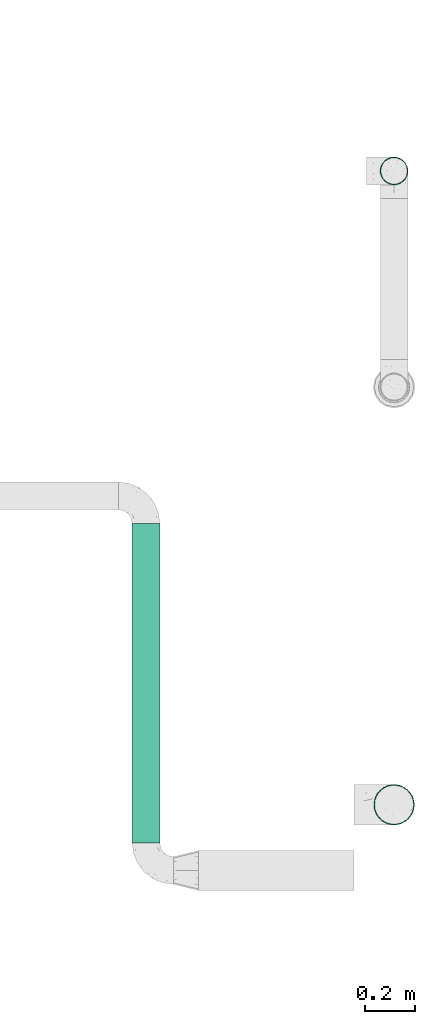
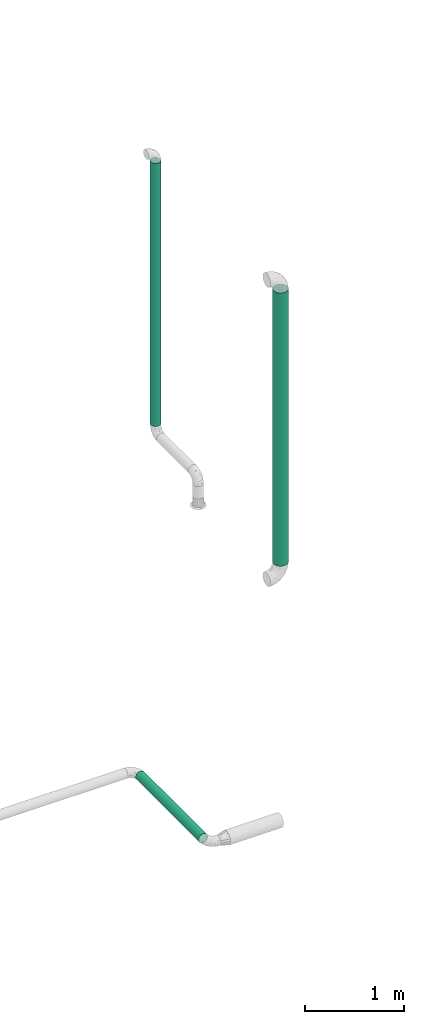
# One storey, part 20 of 123: 3 flow segments.
"""IFC2X3 building model written with IfcOpenShell, lengths in millimetres."""

from ifc_helpers import new_model, entity, si_unit, converted_unit, derived_unit, direction, frame, origin_with_axes, origin_2d_with_axis, place, context, subcontext, project, spatial, hollow_circle, extrude, source, transform, mapped, material, layer, layer_set, layer_usage, type_object, element, save


model = new_model("IFC2X3")

# Units and contexts
model_context = context("Model", 3, precision=1e-05, world=origin_with_axes(), true_north=direction((0.0, 1.0)))
body_context = subcontext(model_context, "Body", "Model", "MODEL_VIEW")
ifc_project = project(units=[si_unit("AREAUNIT", "SQUARE_METRE"), si_unit("VOLUMEUNIT", "CUBIC_METRE", prefix="DECI"), si_unit("TIMEUNIT", "SECOND"), si_unit("THERMODYNAMICTEMPERATUREUNIT", "DEGREE_CELSIUS"), si_unit("PRESSUREUNIT", "PASCAL"), si_unit("MASSUNIT", "GRAM", prefix="KILO"), si_unit("LENGTHUNIT", "METRE", prefix="MILLI"), si_unit("POWERUNIT", "WATT"), si_unit("ELECTRICCURRENTUNIT", "AMPERE"), si_unit("ELECTRICVOLTAGEUNIT", "VOLT"), derived_unit("VOLUMETRICFLOWRATEUNIT", [(si_unit("VOLUMEUNIT", "CUBIC_METRE", prefix="DECI"), 1), (si_unit("TIMEUNIT", "SECOND"), -1)]), derived_unit("LINEARVELOCITYUNIT", [(si_unit("LENGTHUNIT", "METRE"), 1), (si_unit("TIMEUNIT", "SECOND"), -1)]), derived_unit("MASSDENSITYUNIT", [(si_unit("MASSUNIT", "GRAM", prefix="KILO"), 1), (si_unit("VOLUMEUNIT", "CUBIC_METRE"), -1)]), converted_unit("PLANEANGLEUNIT", "DEGREE", entity("IfcRatioMeasure", 0.01745), si_unit("PLANEANGLEUNIT", "RADIAN"), dimensions=[0, 0, 0, 0, 0, 0, 0])], contexts=[model_context])

# Site, building, storey
site_placement = place(None, origin_with_axes())
site = spatial("IfcSite", under=ifc_project, at=site_placement, CompositionType="ELEMENT")
building_placement = place(site_placement, origin_with_axes())
building = spatial("IfcBuilding", under=site, at=building_placement, Name="mc-building", CompositionType="ELEMENT")
storey_placement = place(building_placement, origin_with_axes())
storey = spatial("IfcBuildingStorey", under=building, at=storey_placement, Name="1. Korrus", CompositionType="ELEMENT", Elevation=0.0)

# Flow segments
ifc_material = material(Name="FZ1")
ifc_layer = layer(ifc_material, 0.0)
ifc_layer_set = layer_set([ifc_layer], Name="FZ1")
ifc_layer_usage = layer_usage(ifc_layer_set, "AXIS1", "POSITIVE", 0.0)
duct_segment_type = type_object("IfcDuctSegmentType", PredefinedType="RIGIDSEGMENT")
shared_shape_1 = source(origin_with_axes(), body_context, "Body", "SweptSolid", [
    extrude(hollow_circle(Radius=80.0, WallThickness=2.0, at=origin_2d_with_axis()), frame((0.0, 0.0, 0.0), z_axis=(1.0, 0.0, 0.0), x_axis=(0.0, 1.0, 0.0)), (0.0, 0.0, 1.0), 3365.0),
])
flow_segment_1_placement = place(storey_placement, frame((37769.98441, 4863.15068, 8955.0), z_axis=(-1.0, 0.0, 0.0), x_axis=(0.0, 0.0, -1.0)))
element("IfcFlowSegment", 1, at=flow_segment_1_placement, inside=storey, type_object=duct_segment_type, material=ifc_layer_usage, context=body_context, shape_type="MappedRepresentation", body=[
    mapped(shared_shape_1, transform((0.0, 0.0, 0.0), scale=1.0)),
])
shared_shape_2 = source(origin_with_axes(), body_context, "Body", "SweptSolid", [
    extrude(hollow_circle(Radius=55.0, WallThickness=2.0, at=origin_2d_with_axis()), frame((0.0, 0.0, 0.0), z_axis=(1.0, 0.0, 0.0), x_axis=(0.0, 1.0, 0.0)), (0.0, 0.0, 1.0), 3240.0),
])
flow_segment_2_placement = place(storey_placement, frame((37769.98441, 7384.97206, 9005.0), z_axis=(-1.0, 0.0, 0.0), x_axis=(0.0, 0.0, -1.0)))
element("IfcFlowSegment", 2, at=flow_segment_2_placement, inside=storey, type_object=duct_segment_type, material=ifc_layer_usage, context=body_context, shape_type="MappedRepresentation", body=[
    mapped(shared_shape_2, transform((0.0, 0.0, 0.0), scale=1.0)),
])
shared_shape_3 = source(origin_with_axes(), body_context, "Body", "SweptSolid", [
    extrude(hollow_circle(Radius=55.0, WallThickness=2.0, at=origin_2d_with_axis()), frame((0.0, 0.0, 0.0), z_axis=(1.0, 0.0, 0.0), x_axis=(0.0, 1.0, 0.0)), (0.0, 0.0, 1.0), 1270.8),
])
flow_segment_3_placement = place(storey_placement, frame((36782.68931, 5982.2195, 2625.0), z_axis=(0.0, 0.0, 1.0), x_axis=(0.0, -1.0, 0.0)))
element("IfcFlowSegment", 3, at=flow_segment_3_placement, inside=storey, type_object=duct_segment_type, material=ifc_layer_usage, context=body_context, shape_type="MappedRepresentation", body=[
    mapped(shared_shape_3, transform((0.0, 0.0, 0.0), scale=1.0)),
])

save(model, "model.ifc")
